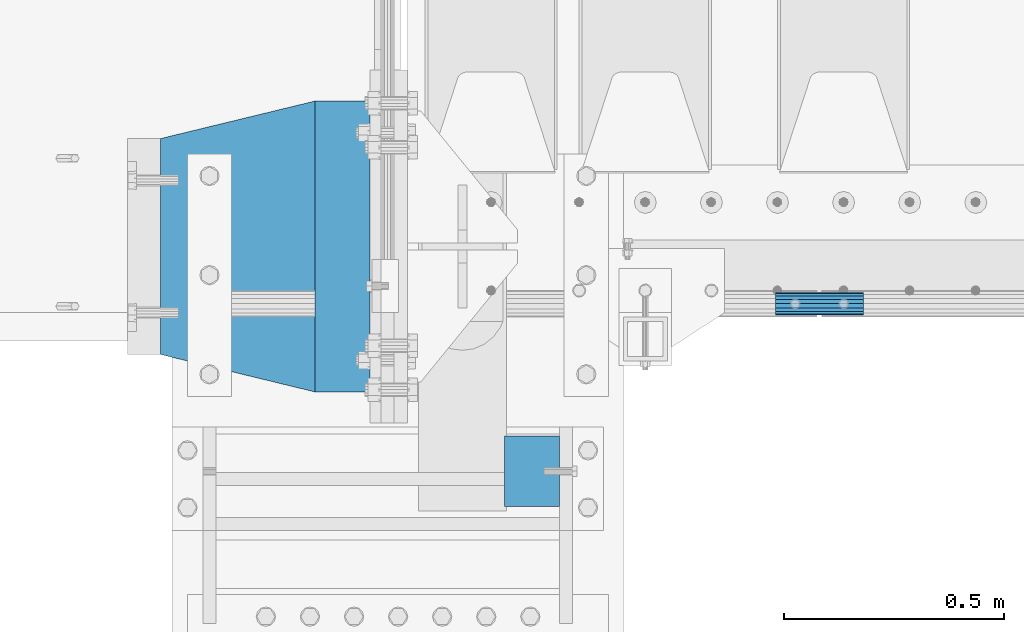
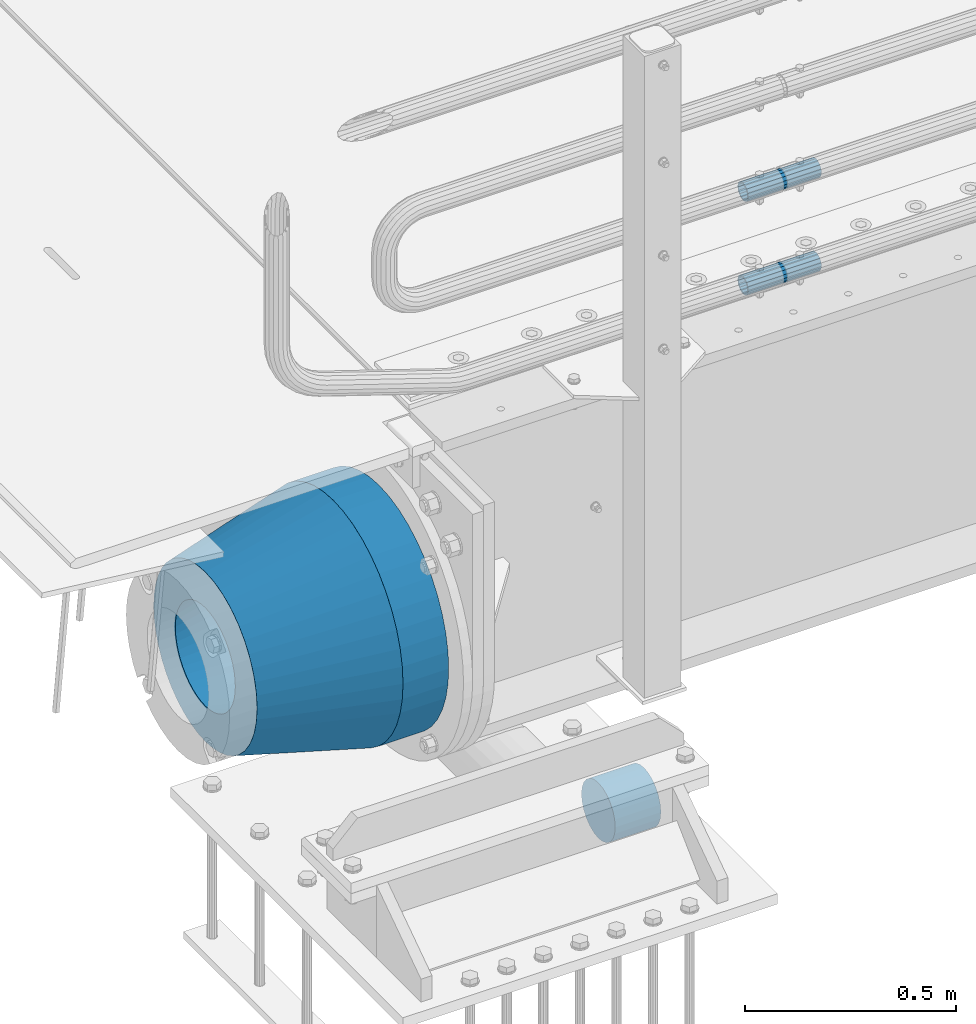
# One storey, part 113 of 208: 5 beams.
"""IFC2X3 building model written with IfcOpenShell, lengths in millimetres."""

from ifc_helpers import new_model, si_unit, frame, origin_with_axes, place, context, subcontext, project, spatial, faceted_brep, material, type_object, element, save


model = new_model("IFC2X3")

# Units and contexts
model_context = context("Model", 3, precision=1e-05, world=origin_with_axes())
body_context = subcontext(model_context, "Body", "Model", "MODEL_VIEW")
ifc_project = project(units=[si_unit("LENGTHUNIT", "METRE", prefix="MILLI"), si_unit("AREAUNIT", "SQUARE_METRE"), si_unit("VOLUMEUNIT", "CUBIC_METRE"), si_unit("MASSUNIT", "GRAM", prefix="KILO"), si_unit("TIMEUNIT", "SECOND"), si_unit("PLANEANGLEUNIT", "RADIAN"), si_unit("SOLIDANGLEUNIT", "STERADIAN"), si_unit("THERMODYNAMICTEMPERATUREUNIT", "DEGREE_CELSIUS"), si_unit("LUMINOUSINTENSITYUNIT", "LUMEN")], contexts=[model_context])

# Site, building, storey
site_placement = place(None, origin_with_axes())
site = spatial("IfcSite", under=ifc_project, at=site_placement, CompositionType="ELEMENT")
building_placement = place(site_placement, origin_with_axes())
building = spatial("IfcBuilding", under=site, at=building_placement, Name="Standard", CompositionType="ELEMENT")
storey_placement = place(building_placement, origin_with_axes())
storey = spatial("IfcBuildingStorey", under=building, at=storey_placement, Name="Undefined", CompositionType="ELEMENT", Elevation=0.0)

# Beams
ifc_material_1 = material()
beam_type_1 = type_object("IfcBeamType", PredefinedType="NOTDEFINED")
beam_1_placement = place(storey_placement, frame((-42219.9999999991, -510.0, -923.000000000004), z_axis=(0.0, 0.0, -1.0), x_axis=(1.0, 0.0, 0.0)))
element("IfcBeam", 1, at=beam_1_placement, inside=storey, type_object=beam_type_1, material=ifc_material_1, context=body_context, shape_type="Brep", body=[
    faceted_brep([(0.0, -80.0, 0.0), (0.0, -77.2740661031254, -20.7055236082017), (125.0, -77.2740661031254, -20.7055236082017), (125.0, -80.0, 0.0), (0.0, -69.2820323027551, -40.0), (125.0, -69.2820323027551, -40.0), (0.0, -56.5685424949238, -56.5685424949238), (125.0, -56.5685424949238, -56.5685424949238), (0.0, -39.9999999999999, -69.2820323027552), (125.0, -39.9999999999999, -69.2820323027552), (0.0, -20.7055236082016, -77.2740661031255), (125.0, -20.7055236082016, -77.2740661031255), (0.0, 0.0, -80.0), (125.0, 0.0, -80.0), (0.0, 20.7055236082017, -77.2740661031255), (125.0, 20.7055236082017, -77.2740661031255), (0.0, 40.0, -69.2820323027551), (125.0, 40.0, -69.2820323027551), (0.0, 56.5685424949238, -56.5685424949238), (125.0, 56.5685424949238, -56.5685424949238), (0.0, 69.2820323027552, -40.0), (125.0, 69.2820323027552, -40.0), (0.0, 77.2740661031255, -20.7055236082016), (125.0, 77.2740661031255, -20.7055236082016), (0.0, 80.0, 0.0), (125.0, 80.0, 0.0), (0.0, 77.2740661031255, 20.7055236082017), (125.0, 77.2740661031255, 20.7055236082017), (0.0, 69.2820323027551, 40.0), (125.0, 69.2820323027551, 40.0), (0.0, 56.5685424949238, 56.5685424949238), (125.0, 56.5685424949238, 56.5685424949238), (0.0, 40.0, 69.2820323027551), (125.0, 40.0, 69.2820323027551), (0.0, 20.7055236082017, 77.2740661031255), (125.0, 20.7055236082017, 77.2740661031255), (0.0, 0.0, 80.0), (125.0, 0.0, 80.0), (0.0, -20.7055236082017, 77.2740661031255), (125.0, -20.7055236082017, 77.2740661031255), (0.0, -40.0, 69.2820323027551), (125.0, -40.0, 69.2820323027551), (0.0, -56.5685424949238, 56.5685424949238), (125.0, -56.5685424949238, 56.5685424949238), (0.0, -69.2820323027551, 40.0), (125.0, -69.2820323027551, 40.0), (0.0, -77.2740661031254, 20.7055236082017), (125.0, -77.2740661031254, 20.7055236082017)], [[[0, 1, 2, 3]], [[1, 4, 5, 2]], [[4, 6, 7, 5]], [[6, 8, 9, 7]], [[8, 10, 11, 9]], [[10, 12, 13, 11]], [[12, 14, 15, 13]], [[14, 16, 17, 15]], [[16, 18, 19, 17]], [[18, 20, 21, 19]], [[20, 22, 23, 21]], [[22, 24, 25, 23]], [[24, 26, 27, 25]], [[26, 28, 29, 27]], [[28, 30, 31, 29]], [[30, 32, 33, 31]], [[32, 34, 35, 33]], [[34, 36, 37, 35]], [[36, 38, 39, 37]], [[38, 40, 41, 39]], [[40, 42, 43, 41]], [[42, 44, 45, 43]], [[44, 46, 47, 45]], [[46, 0, 3, 47]], [[5, 7, 9, 11, 13, 15, 17, 19, 21, 23, 25, 27, 29, 31, 33, 35, 37, 39, 41, 43, 45, 47, 3, 2]], [[46, 44, 42, 40, 38, 36, 34, 32, 30, 28, 26, 24, 22, 20, 18, 16, 14, 12, 10, 8, 6, 4, 1, 0]]]),
])
ifc_material_2 = material()
beam_type_2 = type_object("IfcBeamType", PredefinedType="NOTDEFINED")
beam_2_placement = place(storey_placement, frame((-41605.0024970001, -129.849999999603, 149.849999999725), z_axis=(0.0, 0.0, 1.0), x_axis=(1.0, 0.0, 0.0)))
element("IfcBeam", 2, at=beam_2_placement, inside=storey, type_object=beam_type_2, material=ifc_material_2, context=body_context, shape_type="Brep", body=[
    faceted_brep([(0.0, -21.8999999999996, 0.0), (0.0, -20.2329617619971, 8.38076716879547), (200.0, -20.2329617619971, 8.38076716879547), (200.0, -21.8999999999996, 0.0), (0.0, -15.4856385079856, 15.4856385079854), (200.0, -15.4856385079856, 15.4856385079854), (0.0, -8.3807671687955, 20.2329617619972), (200.0, -8.3807671687955, 20.2329617619972), (0.0, 0.0, 21.9), (200.0, 0.0, 21.9), (0.0, 8.3807671687955, 20.2329617619972), (200.0, 8.3807671687955, 20.2329617619972), (0.0, 15.4856385079856, 15.4856385079854), (200.0, 15.4856385079856, 15.4856385079854), (0.0, 20.2329617619971, 8.38076716879547), (200.0, 20.2329617619971, 8.38076716879547), (0.0, 21.8999999999996, 0.0), (200.0, 21.8999999999996, 0.0), (0.0, 20.2329617619971, -8.38076716879547), (200.0, 20.2329617619971, -8.38076716879547), (0.0, 15.4856385079856, -15.4856385079854), (200.0, 15.4856385079856, -15.4856385079854), (0.0, 8.3807671687955, -20.2329617619972), (200.0, 8.3807671687955, -20.2329617619972), (0.0, 0.0, -21.9), (200.0, 0.0, -21.9), (0.0, -8.3807671687955, -20.2329617619972), (200.0, -8.3807671687955, -20.2329617619972), (0.0, -15.4856385079856, -15.4856385079854), (200.0, -15.4856385079856, -15.4856385079854), (0.0, -20.2329617619971, -8.38076716879547), (200.0, -20.2329617619971, -8.38076716879547), (0.0, -25.5, 0.0), (0.0, -23.5589280790382, -9.7584275253098), (200.0, -23.5589280790382, -9.7584275253098), (200.0, -25.5, 0.0), (0.0, -18.0312229202573, -18.031222920257), (200.0, -18.0312229202573, -18.031222920257), (0.0, -9.75842752530934, -23.5589280790378), (200.0, -9.75842752530934, -23.5589280790378), (0.0, 0.0, -25.5), (200.0, 0.0, -25.5), (0.0, 9.75842752531025, -23.5589280790378), (200.0, 9.75842752531025, -23.5589280790378), (0.0, 18.0312229202573, -18.031222920257), (200.0, 18.0312229202573, -18.031222920257), (0.0, 23.5589280790382, -9.7584275253098), (200.0, 23.5589280790382, -9.7584275253098), (0.0, 25.5, 0.0), (200.0, 25.5, 0.0), (0.0, 23.5589280790382, 9.7584275253098), (200.0, 23.5589280790382, 9.7584275253098), (0.0, 18.0312229202573, 18.031222920257), (200.0, 18.0312229202573, 18.031222920257), (0.0, 9.75842752530934, 23.5589280790378), (200.0, 9.75842752530934, 23.5589280790378), (0.0, 0.0, 25.5), (200.0, 0.0, 25.5), (0.0, -9.75842752530934, 23.5589280790378), (200.0, -9.75842752530934, 23.5589280790378), (0.0, -18.0312229202573, 18.031222920257), (200.0, -18.0312229202573, 18.031222920257), (0.0, -23.5589280790382, 9.7584275253098), (200.0, -23.5589280790382, 9.7584275253098)], [[[0, 1, 2, 3]], [[1, 4, 5, 2]], [[4, 6, 7, 5]], [[6, 8, 9, 7]], [[8, 10, 11, 9]], [[10, 12, 13, 11]], [[12, 14, 15, 13]], [[14, 16, 17, 15]], [[16, 18, 19, 17]], [[18, 20, 21, 19]], [[20, 22, 23, 21]], [[22, 24, 25, 23]], [[24, 26, 27, 25]], [[26, 28, 29, 27]], [[28, 30, 31, 29]], [[30, 0, 3, 31]], [[32, 33, 34, 35]], [[33, 36, 37, 34]], [[36, 38, 39, 37]], [[38, 40, 41, 39]], [[40, 42, 43, 41]], [[42, 44, 45, 43]], [[44, 46, 47, 45]], [[46, 48, 49, 47]], [[48, 50, 51, 49]], [[50, 52, 53, 51]], [[52, 54, 55, 53]], [[54, 56, 57, 55]], [[56, 58, 59, 57]], [[58, 60, 61, 59]], [[60, 62, 63, 61]], [[62, 32, 35, 63]], [[37, 39, 41, 43, 45, 47, 49, 51, 53, 55, 57, 59, 61, 63, 35, 34], [5, 7, 9, 11, 13, 15, 17, 19, 21, 23, 25, 27, 29, 31, 3, 2]], [[62, 60, 58, 56, 54, 52, 50, 48, 46, 44, 42, 40, 38, 36, 33, 32], [30, 28, 26, 24, 22, 20, 18, 16, 14, 12, 10, 8, 6, 4, 1, 0]]]),
])
beam_3_placement = place(storey_placement, frame((-41605.0024970001, -129.849999999603, 420.149999999724), z_axis=(0.0, 0.0, 1.0), x_axis=(1.0, 0.0, 0.0)))
element("IfcBeam", 3, at=beam_3_placement, inside=storey, type_object=beam_type_2, material=ifc_material_2, context=body_context, shape_type="Brep", body=[
    faceted_brep([(0.0, -21.8999999999996, 0.0), (0.0, -20.2329617619971, 8.38076716879547), (200.0, -20.2329617619971, 8.38076716879547), (200.0, -21.8999999999996, 0.0), (0.0, -15.4856385079856, 15.4856385079854), (200.0, -15.4856385079856, 15.4856385079854), (0.0, -8.3807671687955, 20.2329617619972), (200.0, -8.3807671687955, 20.2329617619972), (0.0, 0.0, 21.9), (200.0, 0.0, 21.9), (0.0, 8.3807671687955, 20.2329617619972), (200.0, 8.3807671687955, 20.2329617619972), (0.0, 15.4856385079856, 15.4856385079854), (200.0, 15.4856385079856, 15.4856385079854), (0.0, 20.2329617619971, 8.38076716879547), (200.0, 20.2329617619971, 8.38076716879547), (0.0, 21.8999999999996, 0.0), (200.0, 21.8999999999996, 0.0), (0.0, 20.2329617619971, -8.38076716879547), (200.0, 20.2329617619971, -8.38076716879547), (0.0, 15.4856385079856, -15.4856385079854), (200.0, 15.4856385079856, -15.4856385079854), (0.0, 8.3807671687955, -20.2329617619972), (200.0, 8.3807671687955, -20.2329617619972), (0.0, 0.0, -21.9), (200.0, 0.0, -21.9), (0.0, -8.3807671687955, -20.2329617619972), (200.0, -8.3807671687955, -20.2329617619972), (0.0, -15.4856385079856, -15.4856385079854), (200.0, -15.4856385079856, -15.4856385079854), (0.0, -20.2329617619971, -8.38076716879547), (200.0, -20.2329617619971, -8.38076716879547), (0.0, -25.5, 0.0), (0.0, -23.5589280790382, -9.7584275253098), (200.0, -23.5589280790382, -9.7584275253098), (200.0, -25.5, 0.0), (0.0, -18.0312229202573, -18.031222920257), (200.0, -18.0312229202573, -18.031222920257), (0.0, -9.75842752530934, -23.5589280790378), (200.0, -9.75842752530934, -23.5589280790378), (0.0, 0.0, -25.5), (200.0, 0.0, -25.5), (0.0, 9.75842752531025, -23.5589280790378), (200.0, 9.75842752531025, -23.5589280790378), (0.0, 18.0312229202573, -18.031222920257), (200.0, 18.0312229202573, -18.031222920257), (0.0, 23.5589280790382, -9.7584275253098), (200.0, 23.5589280790382, -9.7584275253098), (0.0, 25.5, 0.0), (200.0, 25.5, 0.0), (0.0, 23.5589280790382, 9.7584275253098), (200.0, 23.5589280790382, 9.7584275253098), (0.0, 18.0312229202573, 18.031222920257), (200.0, 18.0312229202573, 18.031222920257), (0.0, 9.75842752530934, 23.5589280790378), (200.0, 9.75842752530934, 23.5589280790378), (0.0, 0.0, 25.5), (200.0, 0.0, 25.5), (0.0, -9.75842752530934, 23.5589280790378), (200.0, -9.75842752530934, 23.5589280790378), (0.0, -18.0312229202573, 18.031222920257), (200.0, -18.0312229202573, 18.031222920257), (0.0, -23.5589280790382, 9.7584275253098), (200.0, -23.5589280790382, 9.7584275253098)], [[[0, 1, 2, 3]], [[1, 4, 5, 2]], [[4, 6, 7, 5]], [[6, 8, 9, 7]], [[8, 10, 11, 9]], [[10, 12, 13, 11]], [[12, 14, 15, 13]], [[14, 16, 17, 15]], [[16, 18, 19, 17]], [[18, 20, 21, 19]], [[20, 22, 23, 21]], [[22, 24, 25, 23]], [[24, 26, 27, 25]], [[26, 28, 29, 27]], [[28, 30, 31, 29]], [[30, 0, 3, 31]], [[32, 33, 34, 35]], [[33, 36, 37, 34]], [[36, 38, 39, 37]], [[38, 40, 41, 39]], [[40, 42, 43, 41]], [[42, 44, 45, 43]], [[44, 46, 47, 45]], [[46, 48, 49, 47]], [[48, 50, 51, 49]], [[50, 52, 53, 51]], [[52, 54, 55, 53]], [[54, 56, 57, 55]], [[56, 58, 59, 57]], [[58, 60, 61, 59]], [[60, 62, 63, 61]], [[62, 32, 35, 63]], [[37, 39, 41, 43, 45, 47, 49, 51, 53, 55, 57, 59, 61, 63, 35, 34], [5, 7, 9, 11, 13, 15, 17, 19, 21, 23, 25, 27, 29, 31, 3, 2]], [[62, 60, 58, 56, 54, 52, 50, 48, 46, 44, 42, 40, 38, 36, 33, 32], [30, 28, 26, 24, 22, 20, 18, 16, 14, 12, 10, 8, 6, 4, 1, 0]]]),
])
ifc_material_3 = material(Name="STEEL/S355N")
beam_type_3 = type_object("IfcBeamType", PredefinedType="NOTDEFINED")
beam_4_placement = place(storey_placement, frame((-42525.0, 0.0, -515.0), z_axis=(0.0, 0.0, 1.0), x_axis=(-1.0, 0.0, 0.0)))
element("IfcBeam", 4, at=beam_4_placement, inside=storey, type_object=beam_type_3, material=ifc_material_3, context=body_context, shape_type="Brep", body=[
    faceted_brep([(0.0, -215.0, 0.0), (0.0, -212.811610004401, 30.5976902287563), (125.0, -212.811610004401, 30.5976902287563), (125.0, -215.0, 0.0), (0.0, -206.290989327117, 60.5724997209074), (125.0, -206.290989327117, 60.5724997209074), (0.0, -195.570879001221, 89.3142277954056), (125.0, -195.570879001221, 89.3142277954056), (0.0, -180.869509558704, 116.237775752953), (125.0, -180.869509558704, 116.237775752953), (0.0, -162.486158486166, 140.795057798236), (125.0, -162.486158486166, 140.795057798236), (0.0, -140.795057798236, 162.486158486165), (125.0, -140.795057798236, 162.486158486165), (0.0, -116.237775752953, 180.869509558704), (125.0, -116.237775752953, 180.869509558704), (0.0, -89.3142277954057, 195.570879001222), (125.0, -89.3142277954057, 195.570879001222), (0.0, -60.5724997209072, 206.290989327117), (125.0, -60.5724997209072, 206.290989327117), (0.0, -30.5976902287566, 212.811610004401), (125.0, -30.5976902287566, 212.811610004401), (0.0, 0.0, 215.0), (125.0, 0.0, 215.0), (0.0, 30.5976902287566, 212.811610004401), (125.0, 30.5976902287566, 212.811610004401), (0.0, 60.5724997209072, 206.290989327117), (125.0, 60.5724997209072, 206.290989327117), (0.0, 89.3142277954057, 195.570879001221), (125.0, 89.3142277954057, 195.570879001221), (0.0, 116.237775752954, 180.869509558704), (125.0, 116.237775752954, 180.869509558704), (0.0, 140.795057798236, 162.486158486165), (125.0, 140.795057798236, 162.486158486165), (0.0, 162.486158486166, 140.795057798236), (125.0, 162.486158486166, 140.795057798236), (0.0, 180.869509558704, 116.237775752953), (125.0, 180.869509558704, 116.237775752953), (0.0, 195.570879001221, 89.3142277954056), (125.0, 195.570879001221, 89.3142277954056), (0.0, 206.290989327117, 60.5724997209073), (125.0, 206.290989327117, 60.5724997209073), (0.0, 212.811610004401, 30.5976902287563), (125.0, 212.811610004401, 30.5976902287563), (0.0, 215.0, 0.0), (125.0, 215.0, 0.0), (0.0, 212.811610004401, -30.5976902287563), (125.0, 212.811610004401, -30.5976902287563), (0.0, 206.290989327117, -60.5724997209073), (125.0, 206.290989327117, -60.5724997209073), (0.0, 195.570879001221, -89.3142277954056), (125.0, 195.570879001221, -89.3142277954056), (0.0, 180.869509558704, -116.237775752954), (125.0, 180.869509558704, -116.237775752954), (0.0, 162.486158486166, -140.795057798236), (125.0, 162.486158486166, -140.795057798236), (0.0, 140.795057798236, -162.486158486166), (125.0, 140.795057798236, -162.486158486166), (0.0, 116.237775752954, -180.869509558704), (125.0, 116.237775752954, -180.869509558704), (0.0, 89.3142277954057, -195.570879001221), (125.0, 89.3142277954057, -195.570879001221), (0.0, 60.5724997209072, -206.290989327117), (125.0, 60.5724997209072, -206.290989327117), (0.0, 30.5976902287566, -212.811610004401), (125.0, 30.5976902287566, -212.811610004401), (0.0, 0.0, -215.0), (125.0, 0.0, -215.0), (0.0, -30.5976902287566, -212.811610004401), (125.0, -30.5976902287566, -212.811610004401), (0.0, -60.5724997209072, -206.290989327117), (125.0, -60.5724997209072, -206.290989327117), (0.0, -89.3142277954057, -195.570879001221), (125.0, -89.3142277954057, -195.570879001221), (0.0, -116.237775752954, -180.869509558704), (125.0, -116.237775752954, -180.869509558704), (0.0, -140.795057798236, -162.486158486166), (125.0, -140.795057798236, -162.486158486166), (0.0, -162.486158486166, -140.795057798236), (125.0, -162.486158486166, -140.795057798236), (0.0, -180.869509558704, -116.237775752953), (125.0, -180.869509558704, -116.237775752953), (0.0, -195.570879001221, -89.3142277954056), (125.0, -195.570879001221, -89.3142277954056), (0.0, -206.290989327117, -60.5724997209073), (125.0, -206.290989327117, -60.5724997209073), (0.0, -212.811610004401, -30.5976902287563), (125.0, -212.811610004401, -30.5976902287563), (0.0, -330.0, 0.0), (0.0, -326.641075820708, -46.9638966301842), (125.0, -326.641075820708, -46.9638966301842), (125.0, -330.0, 0.0), (0.0, -316.632681292784, -92.9717437576718), (125.0, -316.632681292784, -92.9717437576718), (0.0, -300.178558466991, -137.086954290623), (125.0, -300.178558466991, -137.086954290623), (0.0, -277.613665834289, -178.411469760347), (125.0, -277.613665834289, -178.411469760347), (0.0, -249.397359536905, -216.104042201944), (125.0, -249.397359536905, -216.104042201944), (0.0, -216.104042201944, -249.397359536905), (125.0, -216.104042201944, -249.397359536905), (0.0, -178.411469760347, -277.61366583429), (125.0, -178.411469760347, -277.61366583429), (0.0, -137.086954290622, -300.178558466991), (125.0, -137.086954290622, -300.178558466991), (0.0, -92.9717437576719, -316.632681292784), (125.0, -92.9717437576719, -316.632681292784), (0.0, -46.9638966301836, -326.641075820708), (125.0, -46.9638966301836, -326.641075820708), (0.0, 0.0, -330.0), (125.0, 0.0, -330.0), (0.0, 46.9638966301845, -326.641075820708), (125.0, 46.9638966301845, -326.641075820708), (0.0, 92.9717437576719, -316.632681292784), (125.0, 92.9717437576719, -316.632681292784), (0.0, 137.086954290622, -300.178558466991), (125.0, 137.086954290622, -300.178558466991), (0.0, 178.411469760347, -277.61366583429), (125.0, 178.411469760347, -277.61366583429), (0.0, 216.104042201944, -249.397359536905), (125.0, 216.104042201944, -249.397359536905), (0.0, 249.397359536905, -216.104042201944), (125.0, 249.397359536905, -216.104042201944), (0.0, 277.613665834289, -178.411469760347), (125.0, 277.613665834289, -178.411469760347), (0.0, 300.178558466991, -137.086954290623), (125.0, 300.178558466991, -137.086954290623), (0.0, 316.632681292785, -92.9717437576717), (125.0, 316.632681292785, -92.9717437576717), (0.0, 326.641075820708, -46.9638966301841), (125.0, 326.641075820708, -46.9638966301841), (0.0, 330.0, 0.0), (125.0, 330.0, 0.0), (0.0, 326.641075820708, 46.9638966301841), (125.0, 326.641075820708, 46.9638966301841), (0.0, 316.632681292784, 92.9717437576718), (125.0, 316.632681292784, 92.9717437576718), (0.0, 300.178558466991, 137.086954290622), (125.0, 300.178558466991, 137.086954290622), (0.0, 277.613665834289, 178.411469760347), (125.0, 277.613665834289, 178.411469760347), (0.0, 249.397359536905, 216.104042201944), (125.0, 249.397359536905, 216.104042201944), (0.0, 216.104042201944, 249.397359536905), (125.0, 216.104042201944, 249.397359536905), (0.0, 178.411469760347, 277.61366583429), (125.0, 178.411469760347, 277.61366583429), (0.0, 137.086954290622, 300.178558466991), (125.0, 137.086954290622, 300.178558466991), (0.0, 92.9717437576719, 316.632681292784), (125.0, 92.9717437576719, 316.632681292784), (0.0, 46.9638966301836, 326.641075820708), (125.0, 46.9638966301836, 326.641075820708), (0.0, 0.0, 330.0), (125.0, 0.0, 330.0), (0.0, -46.9638966301845, 326.641075820708), (125.0, -46.9638966301845, 326.641075820708), (0.0, -92.9717437576719, 316.632681292784), (125.0, -92.9717437576719, 316.632681292784), (0.0, -137.086954290622, 300.178558466991), (125.0, -137.086954290622, 300.178558466991), (0.0, -178.411469760347, 277.61366583429), (125.0, -178.411469760347, 277.61366583429), (0.0, -216.104042201944, 249.397359536905), (125.0, -216.104042201944, 249.397359536905), (0.0, -249.397359536905, 216.104042201944), (125.0, -249.397359536905, 216.104042201944), (0.0, -277.613665834289, 178.411469760347), (125.0, -277.613665834289, 178.411469760347), (0.0, -300.178558466991, 137.086954290623), (125.0, -300.178558466991, 137.086954290623), (0.0, -316.632681292784, 92.9717437576718), (125.0, -316.632681292784, 92.9717437576718), (0.0, -326.641075820708, 46.9638966301841), (125.0, -326.641075820708, 46.9638966301841)], [[[0, 1, 2, 3]], [[1, 4, 5, 2]], [[4, 6, 7, 5]], [[6, 8, 9, 7]], [[8, 10, 11, 9]], [[10, 12, 13, 11]], [[12, 14, 15, 13]], [[14, 16, 17, 15]], [[16, 18, 19, 17]], [[18, 20, 21, 19]], [[20, 22, 23, 21]], [[22, 24, 25, 23]], [[24, 26, 27, 25]], [[26, 28, 29, 27]], [[28, 30, 31, 29]], [[30, 32, 33, 31]], [[32, 34, 35, 33]], [[34, 36, 37, 35]], [[36, 38, 39, 37]], [[38, 40, 41, 39]], [[40, 42, 43, 41]], [[42, 44, 45, 43]], [[44, 46, 47, 45]], [[46, 48, 49, 47]], [[48, 50, 51, 49]], [[50, 52, 53, 51]], [[52, 54, 55, 53]], [[54, 56, 57, 55]], [[56, 58, 59, 57]], [[58, 60, 61, 59]], [[60, 62, 63, 61]], [[62, 64, 65, 63]], [[64, 66, 67, 65]], [[66, 68, 69, 67]], [[68, 70, 71, 69]], [[70, 72, 73, 71]], [[72, 74, 75, 73]], [[74, 76, 77, 75]], [[76, 78, 79, 77]], [[78, 80, 81, 79]], [[80, 82, 83, 81]], [[82, 84, 85, 83]], [[84, 86, 87, 85]], [[86, 0, 3, 87]], [[88, 89, 90, 91]], [[89, 92, 93, 90]], [[92, 94, 95, 93]], [[94, 96, 97, 95]], [[96, 98, 99, 97]], [[98, 100, 101, 99]], [[100, 102, 103, 101]], [[102, 104, 105, 103]], [[104, 106, 107, 105]], [[106, 108, 109, 107]], [[108, 110, 111, 109]], [[110, 112, 113, 111]], [[112, 114, 115, 113]], [[114, 116, 117, 115]], [[116, 118, 119, 117]], [[118, 120, 121, 119]], [[120, 122, 123, 121]], [[122, 124, 125, 123]], [[124, 126, 127, 125]], [[126, 128, 129, 127]], [[128, 130, 131, 129]], [[130, 132, 133, 131]], [[132, 134, 135, 133]], [[134, 136, 137, 135]], [[136, 138, 139, 137]], [[138, 140, 141, 139]], [[140, 142, 143, 141]], [[142, 144, 145, 143]], [[144, 146, 147, 145]], [[146, 148, 149, 147]], [[148, 150, 151, 149]], [[150, 152, 153, 151]], [[152, 154, 155, 153]], [[154, 156, 157, 155]], [[156, 158, 159, 157]], [[158, 160, 161, 159]], [[160, 162, 163, 161]], [[162, 164, 165, 163]], [[164, 166, 167, 165]], [[166, 168, 169, 167]], [[168, 170, 171, 169]], [[170, 172, 173, 171]], [[172, 174, 175, 173]], [[174, 88, 91, 175]], [[93, 95, 97, 99, 101, 103, 105, 107, 109, 111, 113, 115, 117, 119, 121, 123, 125, 127, 129, 131, 133, 135, 137, 139, 141, 143, 145, 147, 149, 151, 153, 155, 157, 159, 161, 163, 165, 167, 169, 171, 173, 175, 91, 90], [5, 7, 9, 11, 13, 15, 17, 19, 21, 23, 25, 27, 29, 31, 33, 35, 37, 39, 41, 43, 45, 47, 49, 51, 53, 55, 57, 59, 61, 63, 65, 67, 69, 71, 73, 75, 77, 79, 81, 83, 85, 87, 3, 2]], [[174, 172, 170, 168, 166, 164, 162, 160, 158, 156, 154, 152, 150, 148, 146, 144, 142, 140, 138, 136, 134, 132, 130, 128, 126, 124, 122, 120, 118, 116, 114, 112, 110, 108, 106, 104, 102, 100, 98, 96, 94, 92, 89, 88], [86, 84, 82, 80, 78, 76, 74, 72, 70, 68, 66, 64, 62, 60, 58, 56, 54, 52, 50, 48, 46, 44, 42, 40, 38, 36, 34, 32, 30, 28, 26, 24, 22, 20, 18, 16, 14, 12, 10, 8, 6, 4, 1, 0]]]),
])
ifc_material_4 = material(Name="SCN-500-E2")
beam_type_4 = type_object("IfcBeamType", PredefinedType="NOTDEFINED")
beam_5_placement = place(storey_placement, frame((-42650.0, 0.0, -515.0), z_axis=(0.0, 0.0, 1.0), x_axis=(-1.0, 0.0, 0.0)))
element("IfcBeam", 5, at=beam_5_placement, inside=storey, type_object=beam_type_4, material=ifc_material_4, context=body_context, shape_type="Brep", body=[
    faceted_brep([(0.0, -330.0, 0.0), (0.0, -326.641075820708, -46.9638966301842), (350.0, -242.506253260828, -34.8671353769549), (350.0, -245.0, 0.0), (0.0, -316.632681292784, -92.9717437576718), (350.0, -235.075778535552, -69.0244764261503), (0.0, -300.178558466991, -137.086954290623), (350.0, -222.859838861857, -101.776678185462), (0.0, -277.613665834289, -178.411469760347), (350.0, -206.107115543639, -132.457000276621), (0.0, -249.397359536905, -216.104042201944), (350.0, -185.158645716793, -160.440879816595), (0.0, -216.104042201944, -249.397359536905), (350.0, -160.440879816595, -185.158645716793), (0.0, -178.411469760347, -277.61366583429), (350.0, -132.457000276621, -206.107115543639), (0.0, -137.086954290622, -300.178558466991), (350.0, -101.776678185463, -222.859838861857), (0.0, -92.9717437576719, -316.632681292784), (350.0, -69.0244764261506, -235.075778535552), (0.0, -46.9638966301836, -326.641075820708), (350.0, -34.867135376955, -242.506253260829), (0.0, 0.0, -330.0), (350.0, 0.0, -245.0), (0.0, 46.9638966301845, -326.641075820708), (350.0, 34.867135376955, -242.506253260829), (0.0, 92.9717437576719, -316.632681292784), (350.0, 69.0244764261506, -235.075778535552), (0.0, 137.086954290622, -300.178558466991), (350.0, 101.776678185463, -222.859838861857), (0.0, 178.411469760347, -277.61366583429), (350.0, 132.457000276621, -206.107115543639), (0.0, 216.104042201944, -249.397359536905), (350.0, 160.440879816595, -185.158645716793), (0.0, 249.397359536905, -216.104042201944), (350.0, 185.158645716793, -160.440879816595), (0.0, 277.613665834289, -178.411469760347), (350.0, 206.107115543639, -132.457000276621), (0.0, 300.178558466991, -137.086954290623), (350.0, 222.859838861857, -101.776678185462), (0.0, 316.632681292785, -92.9717437576717), (350.0, 235.075778535552, -69.0244764261502), (0.0, 326.641075820708, -46.9638966301841), (350.0, 242.506253260828, -34.8671353769548), (0.0, 330.0, 0.0), (350.0, 245.0, 0.0), (0.0, 326.641075820708, 46.9638966301841), (350.0, 242.506253260828, 34.8671353769549), (0.0, 316.632681292784, 92.9717437576718), (350.0, 235.075778535552, 69.0244764261503), (0.0, 300.178558466991, 137.086954290622), (350.0, 222.859838861857, 101.776678185462), (0.0, 277.613665834289, 178.411469760347), (350.0, 206.107115543639, 132.457000276621), (0.0, 249.397359536905, 216.104042201944), (350.0, 185.158645716793, 160.440879816595), (0.0, 216.104042201944, 249.397359536905), (350.0, 160.440879816595, 185.158645716793), (0.0, 178.411469760347, 277.61366583429), (350.0, 132.457000276621, 206.107115543639), (0.0, 137.086954290622, 300.178558466991), (350.0, 101.776678185463, 222.859838861857), (0.0, 92.9717437576719, 316.632681292784), (350.0, 69.0244764261506, 235.075778535552), (0.0, 46.9638966301836, 326.641075820708), (350.0, 34.867135376955, 242.506253260829), (0.0, 0.0, 330.0), (350.0, 0.0, 245.0), (0.0, -46.9638966301845, 326.641075820708), (350.0, -34.867135376955, 242.506253260829), (0.0, -92.9717437576719, 316.632681292784), (350.0, -69.0244764261506, 235.075778535552), (0.0, -137.086954290622, 300.178558466991), (350.0, -101.776678185463, 222.859838861857), (0.0, -178.411469760347, 277.61366583429), (350.0, -132.457000276621, 206.107115543639), (0.0, -216.104042201944, 249.397359536905), (350.0, -160.440879816595, 185.158645716793), (0.0, -249.397359536905, 216.104042201944), (350.0, -185.158645716793, 160.440879816595), (0.0, -277.613665834289, 178.411469760347), (350.0, -206.107115543639, 132.457000276621), (0.0, -300.178558466991, 137.086954290623), (350.0, -222.859838861857, 101.776678185462), (0.0, -316.632681292784, 92.9717437576718), (350.0, -235.075778535552, 69.0244764261503), (0.0, -326.641075820708, 46.9638966301841), (350.0, -242.506253260828, 34.8671353769549), (0.0, -227.093265923131, 0.0), (0.0, -224.781783917484, 32.3187414128026), (350.0, -140.646961357605, 20.2219801595734), (350.0, -142.093265923131, 0.0), (0.0, -217.894393008413, 63.9795664499945), (350.0, -136.337490251181, 40.032299118473), (0.0, -206.571300613232, 94.3379520160985), (350.0, -129.252581008098, 59.0276759109381), (0.0, -191.043012240005, 122.775888927343), (350.0, -119.536461949355, 76.8214194436173), (0.0, -171.625639060125, 148.714462796454), (350.0, -107.386925240013, 93.0513004111044), (0.0, -148.714462796454, 171.625639060125), (350.0, -93.0513004111044, 107.386925240013), (0.0, -122.775888927343, 191.043012240005), (350.0, -76.8214194436177, 119.536461949355), (0.0, -94.3379520160988, 206.571300613232), (350.0, -59.0276759109383, 129.252581008098), (0.0, -63.9795664499943, 217.894393008413), (350.0, -40.032299118473, 136.337490251181), (0.0, -32.3187414128024, 224.781783917484), (350.0, -20.2219801595729, 140.646961357605), (0.0, 0.0, 227.093265923131), (350.0, 0.0, 142.093265923131), (0.0, 32.3187414128024, 224.781783917484), (350.0, 20.2219801595729, 140.646961357605), (0.0, 63.9795664499943, 217.894393008413), (350.0, 40.032299118473, 136.337490251181), (0.0, 94.3379520160988, 206.571300613232), (350.0, 59.0276759109383, 129.252581008098), (0.0, 122.775888927343, 191.043012240005), (350.0, 76.8214194436177, 119.536461949355), (0.0, 148.714462796454, 171.625639060125), (350.0, 93.0513004111044, 107.386925240013), (0.0, 171.625639060125, 148.714462796454), (350.0, 107.386925240013, 93.0513004111044), (0.0, 191.043012240005, 122.775888927343), (350.0, 119.536461949355, 76.8214194436174), (0.0, 206.571300613232, 94.3379520160985), (350.0, 129.252581008098, 59.0276759109382), (0.0, 217.894393008413, 63.9795664499945), (350.0, 136.337490251181, 40.032299118473), (0.0, 224.781783917484, 32.3187414128025), (350.0, 140.646961357605, 20.2219801595733), (0.0, 227.093265923131, 0.0), (350.0, 142.093265923131, 0.0), (0.0, 224.781783917484, -32.3187414128026), (350.0, 140.646961357605, -20.2219801595734), (0.0, 217.894393008413, -63.9795664499945), (350.0, 136.337490251181, -40.032299118473), (0.0, 206.571300613232, -94.3379520160985), (350.0, 129.252581008098, -59.0276759109381), (0.0, 191.043012240005, -122.775888927343), (350.0, 119.536461949355, -76.8214194436174), (0.0, 171.625639060125, -148.714462796454), (350.0, 107.386925240013, -93.0513004111044), (0.0, 148.714462796454, -171.625639060125), (350.0, 93.0513004111044, -107.386925240013), (0.0, 122.775888927343, -191.043012240005), (350.0, 76.8214194436177, -119.536461949355), (0.0, 94.3379520160988, -206.571300613232), (350.0, 59.0276759109383, -129.252581008098), (0.0, 63.9795664499943, -217.894393008413), (350.0, 40.032299118473, -136.337490251181), (0.0, 32.3187414128024, -224.781783917484), (350.0, 20.2219801595729, -140.646961357605), (0.0, 0.0, -227.093265923131), (350.0, 0.0, -142.093265923131), (0.0, -32.3187414128024, -224.781783917484), (350.0, -20.2219801595729, -140.646961357605), (0.0, -63.9795664499943, -217.894393008413), (350.0, -40.032299118473, -136.337490251181), (0.0, -94.3379520160988, -206.571300613232), (350.0, -59.0276759109383, -129.252581008098), (0.0, -122.775888927343, -191.043012240005), (350.0, -76.8214194436177, -119.536461949355), (0.0, -148.714462796454, -171.625639060125), (350.0, -93.0513004111044, -107.386925240013), (0.0, -171.625639060125, -148.714462796454), (350.0, -107.386925240013, -93.0513004111044), (0.0, -191.043012240005, -122.775888927343), (350.0, -119.536461949355, -76.8214194436174), (0.0, -206.571300613232, -94.3379520160985), (350.0, -129.252581008098, -59.0276759109381), (0.0, -217.894393008413, -63.9795664499945), (350.0, -136.337490251181, -40.032299118473), (0.0, -224.781783917484, -32.3187414128026), (350.0, -140.646961357605, -20.2219801595734)], [[[0, 1, 2, 3]], [[1, 4, 5, 2]], [[4, 6, 7, 5]], [[6, 8, 9, 7]], [[8, 10, 11, 9]], [[10, 12, 13, 11]], [[12, 14, 15, 13]], [[14, 16, 17, 15]], [[16, 18, 19, 17]], [[18, 20, 21, 19]], [[20, 22, 23, 21]], [[22, 24, 25, 23]], [[24, 26, 27, 25]], [[26, 28, 29, 27]], [[28, 30, 31, 29]], [[30, 32, 33, 31]], [[32, 34, 35, 33]], [[34, 36, 37, 35]], [[36, 38, 39, 37]], [[38, 40, 41, 39]], [[40, 42, 43, 41]], [[42, 44, 45, 43]], [[44, 46, 47, 45]], [[46, 48, 49, 47]], [[48, 50, 51, 49]], [[50, 52, 53, 51]], [[52, 54, 55, 53]], [[54, 56, 57, 55]], [[56, 58, 59, 57]], [[58, 60, 61, 59]], [[60, 62, 63, 61]], [[62, 64, 65, 63]], [[64, 66, 67, 65]], [[66, 68, 69, 67]], [[68, 70, 71, 69]], [[70, 72, 73, 71]], [[72, 74, 75, 73]], [[74, 76, 77, 75]], [[76, 78, 79, 77]], [[78, 80, 81, 79]], [[80, 82, 83, 81]], [[82, 84, 85, 83]], [[84, 86, 87, 85]], [[86, 0, 3, 87]], [[88, 89, 90, 91]], [[89, 92, 93, 90]], [[92, 94, 95, 93]], [[94, 96, 97, 95]], [[96, 98, 99, 97]], [[98, 100, 101, 99]], [[100, 102, 103, 101]], [[102, 104, 105, 103]], [[104, 106, 107, 105]], [[106, 108, 109, 107]], [[108, 110, 111, 109]], [[110, 112, 113, 111]], [[112, 114, 115, 113]], [[114, 116, 117, 115]], [[116, 118, 119, 117]], [[118, 120, 121, 119]], [[120, 122, 123, 121]], [[122, 124, 125, 123]], [[124, 126, 127, 125]], [[126, 128, 129, 127]], [[128, 130, 131, 129]], [[130, 132, 133, 131]], [[132, 134, 135, 133]], [[134, 136, 137, 135]], [[136, 138, 139, 137]], [[138, 140, 141, 139]], [[140, 142, 143, 141]], [[142, 144, 145, 143]], [[144, 146, 147, 145]], [[146, 148, 149, 147]], [[148, 150, 151, 149]], [[150, 152, 153, 151]], [[152, 154, 155, 153]], [[154, 156, 157, 155]], [[156, 158, 159, 157]], [[158, 160, 161, 159]], [[160, 162, 163, 161]], [[162, 164, 165, 163]], [[164, 166, 167, 165]], [[166, 168, 169, 167]], [[168, 170, 171, 169]], [[170, 172, 173, 171]], [[172, 174, 175, 173]], [[174, 88, 91, 175]], [[5, 7, 9, 11, 13, 15, 17, 19, 21, 23, 25, 27, 29, 31, 33, 35, 37, 39, 41, 43, 45, 47, 49, 51, 53, 55, 57, 59, 61, 63, 65, 67, 69, 71, 73, 75, 77, 79, 81, 83, 85, 87, 3, 2], [93, 95, 97, 99, 101, 103, 105, 107, 109, 111, 113, 115, 117, 119, 121, 123, 125, 127, 129, 131, 133, 135, 137, 139, 141, 143, 145, 147, 149, 151, 153, 155, 157, 159, 161, 163, 165, 167, 169, 171, 173, 175, 91, 90]], [[86, 84, 82, 80, 78, 76, 74, 72, 70, 68, 66, 64, 62, 60, 58, 56, 54, 52, 50, 48, 46, 44, 42, 40, 38, 36, 34, 32, 30, 28, 26, 24, 22, 20, 18, 16, 14, 12, 10, 8, 6, 4, 1, 0], [174, 172, 170, 168, 166, 164, 162, 160, 158, 156, 154, 152, 150, 148, 146, 144, 142, 140, 138, 136, 134, 132, 130, 128, 126, 124, 122, 120, 118, 116, 114, 112, 110, 108, 106, 104, 102, 100, 98, 96, 94, 92, 89, 88]]]),
])

save(model, "model.ifc")
